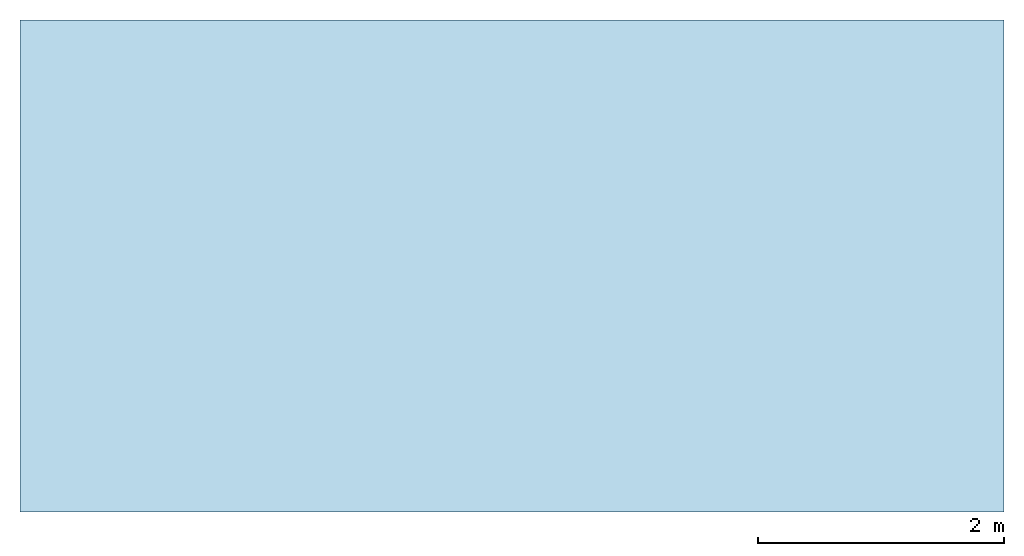
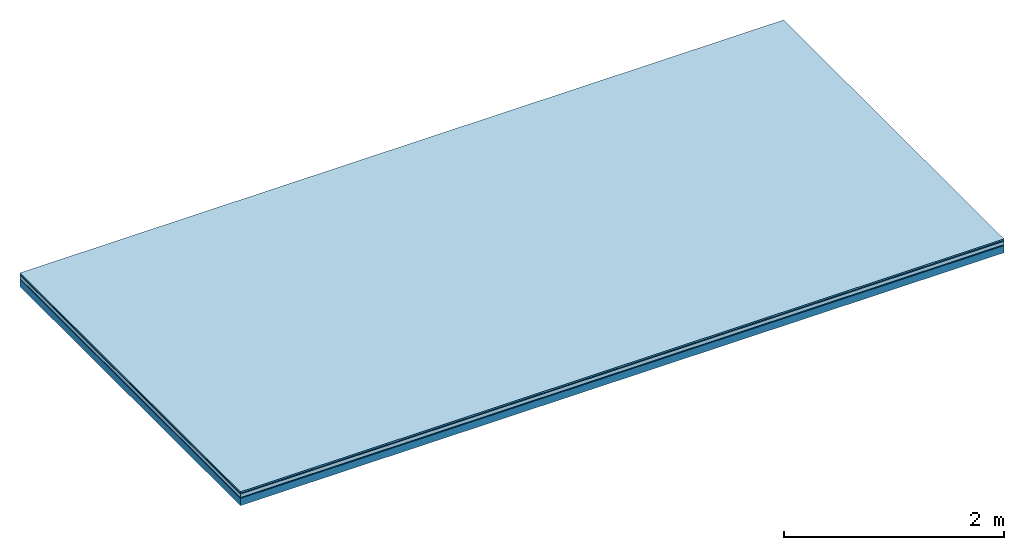
# One storey: 5 plates, 1 member, 1 element without a shape of its own.
"""IFC4 building model written with IfcOpenShell, lengths in metres."""

from ifc_helpers import new_model, si_unit, derived_unit, direction, frame, frame_2d, origin, origin_with_axes, place, context, project, spatial, rectangle, extrude, material, layer, layer_set, type_object, element, aggregate, save


model = new_model("IFC4")

# Units and contexts
plan_context = context("Plan", 3, precision=1e-05, world=origin(), true_north=direction((0.0, 1.0)))
model_context = context("Model", 3, precision=1e-05, world=origin(), true_north=direction((0.0, 1.0)))
ifc_project = project(units=[si_unit("LENGTHUNIT", "METRE"), derived_unit("SOUNDPRESSUREUNIT", [(si_unit("PRESSUREUNIT", "PASCAL", prefix="MICRO"), 0)]), si_unit("ENERGYUNIT", "JOULE", prefix="MEGA"), si_unit("MASSUNIT", "GRAM", prefix="KILO"), derived_unit("THERMALTRANSMITTANCEUNIT", [(si_unit("POWERUNIT", "WATT"), 1), (si_unit("AREAUNIT", "SQUARE_METRE"), -1), (si_unit("THERMODYNAMICTEMPERATUREUNIT", "KELVIN"), -1)]), derived_unit("AREADENSITYUNIT", [(si_unit("MASSUNIT", "GRAM", prefix="KILO"), 1), (si_unit("AREAUNIT", "SQUARE_METRE"), -1)]), derived_unit("USERDEFINED", [(si_unit("ENERGYUNIT", "JOULE", prefix="MEGA"), 1), (si_unit("AREAUNIT", "SQUARE_METRE"), -1)])], contexts=[plan_context, model_context])

# Site, building, storey
site = spatial("IfcSite", under=ifc_project)
building_placement = place(None, origin())
building = spatial("IfcBuilding", under=site, at=building_placement)
storey_placement = place(building_placement, origin())
storey = spatial("IfcBuildingStorey", under=building, at=storey_placement)

# Slab, member, plates
ifc_material_1 = material(Category="11.013")
ifc_layer_1 = layer(ifc_material_1, 0.015, Name="Flooring")
ifc_material_2 = material(Category="03.007")
ifc_layer_2 = layer(ifc_material_2, 0.01, Name="layer")
ifc_material_3 = material(Name="Floor heating system Therm38 standard", Category="03.007")
ifc_layer_3 = layer(ifc_material_3, 0.038, Name="On-material")
ifc_material_4 = material(Name="Wood fiber generic product", Category="10.009")
ifc_layer_4 = layer(ifc_material_4, 0.01, Name="Impact sound insulation")
ifc_material_5 = material(Name="protection", Category="09.007")
ifc_layer_5 = layer(ifc_material_5, 0.0005, Name="Sub-floor")
ifc_material_6 = material(Name="no composite action")
ifc_layer_6 = layer(ifc_material_6, 0.0, Name="Bond")
ifc_layer_7 = layer(None, 0.08, Name="Supporting structure")
ifc_layer_set = layer_set([ifc_layer_1, ifc_layer_2, ifc_layer_3, ifc_layer_4, ifc_layer_5, ifc_layer_6, ifc_layer_7])
slab_type = type_object("IfcSlabType", Name="A2031", PredefinedType="NOTDEFINED", material=ifc_layer_set)
slab_placement = place(None, frame((0.0, 0.0, 0.0), z_axis=(0.0, 0.0, -1.0), x_axis=(1.0, 0.0, 0.0)))
slab = element("IfcSlab", 1, at=slab_placement, inside=storey, type_object=slab_type, material=ifc_layer_set, Name="Slab #1")
ifc_material_7 = material(Name="Solid timber panel")
member_placement = place(slab_placement, origin())
member = element("IfcMember", 2, at=member_placement, material=ifc_material_7, Name="Supporting structure", context=plan_context, shape_type="SweptSolid", body=[
    extrude(rectangle(XDim=1.0, YDim=0.08, at=frame_2d((0.5, 0.04), x_axis=(1.0, 0.0))), frame((0.0, 4.0, 0.0735), z_axis=(0.0, -1.0, 0.0), x_axis=(1.0, 0.0, 0.0)), (0.0, 0.0, 1.0), 4.0),
    extrude(rectangle(XDim=1.0, YDim=0.08, at=frame_2d((0.5, 0.04), x_axis=(1.0, 0.0))), frame((1.0, 4.0, 0.0735), z_axis=(0.0, -1.0, 0.0), x_axis=(1.0, 0.0, 0.0)), (0.0, 0.0, 1.0), 4.0),
    extrude(rectangle(XDim=1.0, YDim=0.08, at=frame_2d((0.5, 0.04), x_axis=(1.0, 0.0))), frame((2.0, 4.0, 0.0735), z_axis=(0.0, -1.0, 0.0), x_axis=(1.0, 0.0, 0.0)), (0.0, 0.0, 1.0), 4.0),
    extrude(rectangle(XDim=1.0, YDim=0.08, at=frame_2d((0.5, 0.04), x_axis=(1.0, 0.0))), frame((3.0, 4.0, 0.0735), z_axis=(0.0, -1.0, 0.0), x_axis=(1.0, 0.0, 0.0)), (0.0, 0.0, 1.0), 4.0),
    extrude(rectangle(XDim=1.0, YDim=0.08, at=frame_2d((0.5, 0.04), x_axis=(1.0, 0.0))), frame((4.0, 4.0, 0.0735), z_axis=(0.0, -1.0, 0.0), x_axis=(1.0, 0.0, 0.0)), (0.0, 0.0, 1.0), 4.0),
    extrude(rectangle(XDim=1.0, YDim=0.08, at=frame_2d((0.5, 0.04), x_axis=(1.0, 0.0))), frame((5.0, 4.0, 0.0735), z_axis=(0.0, -1.0, 0.0), x_axis=(1.0, 0.0, 0.0)), (0.0, 0.0, 1.0), 4.0),
    extrude(rectangle(XDim=1.0, YDim=0.08, at=frame_2d((0.5, 0.04), x_axis=(1.0, 0.0))), frame((6.0, 4.0, 0.0735), z_axis=(0.0, -1.0, 0.0), x_axis=(1.0, 0.0, 0.0)), (0.0, 0.0, 1.0), 4.0),
    extrude(rectangle(XDim=1.0, YDim=0.08, at=frame_2d((0.5, 0.04), x_axis=(1.0, 0.0))), frame((7.0, 4.0, 0.0735), z_axis=(0.0, -1.0, 0.0), x_axis=(1.0, 0.0, 0.0)), (0.0, 0.0, 1.0), 4.0),
])
plate_1_placement = place(slab_placement, origin())
plate_1 = element("IfcPlate", 3, at=plate_1_placement, material=ifc_material_1, Name="Flooring", context=plan_context, shape_type="SweptSolid", body=[
    extrude(rectangle(XDim=8.0, YDim=4.0, at=frame_2d((4.0, 2.0), x_axis=(1.0, 0.0))), origin_with_axes(), (0.0, 0.0, 1.0), 0.015),
])
plate_2_placement = place(slab_placement, origin())
plate_2 = element("IfcPlate", 4, at=plate_2_placement, material=ifc_material_2, Name="layer", context=plan_context, shape_type="SweptSolid", body=[
    extrude(rectangle(XDim=8.0, YDim=4.0, at=frame_2d((4.0, 2.0), x_axis=(1.0, 0.0))), frame((0.0, 0.0, 0.015), z_axis=(0.0, 0.0, 1.0), x_axis=(1.0, 0.0, 0.0)), (0.0, 0.0, 1.0), 0.01),
])
plate_3_placement = place(slab_placement, origin())
plate_3 = element("IfcPlate", 5, at=plate_3_placement, material=ifc_material_3, Name="On-material", context=plan_context, shape_type="SweptSolid", body=[
    extrude(rectangle(XDim=8.0, YDim=4.0, at=frame_2d((4.0, 2.0), x_axis=(1.0, 0.0))), frame((0.0, 0.0, 0.025), z_axis=(0.0, 0.0, 1.0), x_axis=(1.0, 0.0, 0.0)), (0.0, 0.0, 1.0), 0.038),
])
plate_4_placement = place(slab_placement, origin())
plate_4 = element("IfcPlate", 6, at=plate_4_placement, material=ifc_material_4, Name="Impact sound insulation", context=plan_context, shape_type="SweptSolid", body=[
    extrude(rectangle(XDim=8.0, YDim=4.0, at=frame_2d((4.0, 2.0), x_axis=(1.0, 0.0))), frame((0.0, 0.0, 0.063), z_axis=(0.0, 0.0, 1.0), x_axis=(1.0, 0.0, 0.0)), (0.0, 0.0, 1.0), 0.01),
])
plate_5_placement = place(slab_placement, origin())
plate_5 = element("IfcPlate", 7, at=plate_5_placement, material=ifc_material_5, Name="Sub-floor", context=plan_context, shape_type="SweptSolid", body=[
    extrude(rectangle(XDim=8.0, YDim=4.0, at=frame_2d((4.0, 2.0), x_axis=(1.0, 0.0))), frame((0.0, 0.0, 0.073), z_axis=(0.0, 0.0, 1.0), x_axis=(1.0, 0.0, 0.0)), (0.0, 0.0, 1.0), 0.0005),
])
aggregate(slab, [plate_1, plate_2, plate_3, plate_4, plate_5, member])

save(model, "model.ifc")
